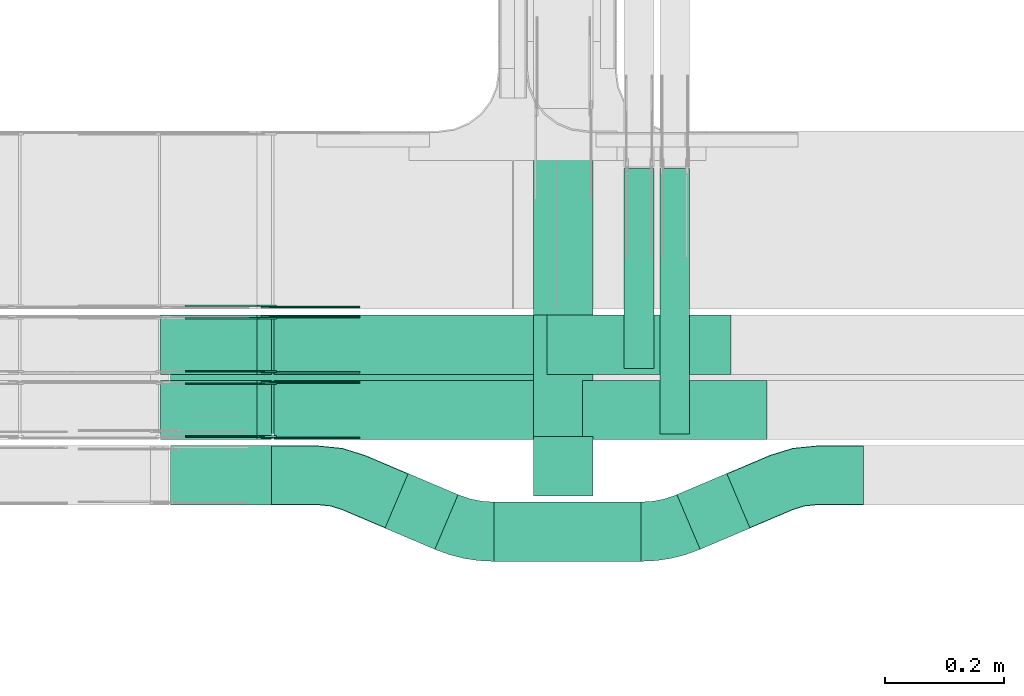
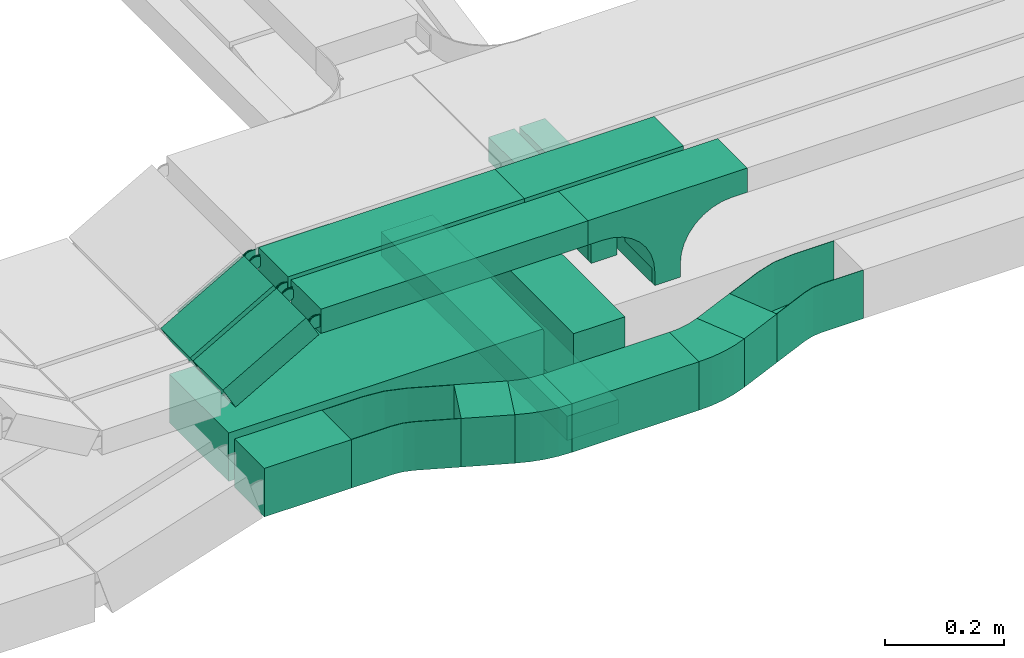
# One storey, part 12 of 28: 17 flow fittings, 13 flow segments.
"""IFC2X3 building model written with IfcOpenShell, lengths in millimetres."""

from ifc_helpers import new_model, entity, si_unit, converted_unit, derived_unit, direction, frame, frame_2d, origin, origin_2d_with_axis, place, context, subcontext, project, spatial, polyline, circle_curve, parameter, trimmed, segment, composite_curve, rectangle, outline, extrude, faceted_brep, source, transform, mapped, material, material_list, type_object, type_shapes, element, save


model = new_model("IFC2X3")

# Units and contexts
model_context = context("Model", 3, precision=0.01, world=origin(), true_north=direction((6.12303176911189e-17, 1.0)))
body_context = subcontext(model_context, "Body", "Model", "MODEL_VIEW")
ifc_project = project(units=[si_unit("LENGTHUNIT", "METRE", prefix="MILLI"), si_unit("AREAUNIT", "SQUARE_METRE"), si_unit("VOLUMEUNIT", "CUBIC_METRE"), converted_unit("PLANEANGLEUNIT", "DEGREE", entity("IfcRatioMeasure", 0.0174532925199433), si_unit("PLANEANGLEUNIT", "RADIAN"), dimensions=[0, 0, 0, 0, 0, 0, 0]), si_unit("MASSUNIT", "GRAM", prefix="KILO"), derived_unit("MASSDENSITYUNIT", [(si_unit("MASSUNIT", "GRAM", prefix="KILO"), 1), (si_unit("LENGTHUNIT", "METRE"), -3)]), derived_unit("MOMENTOFINERTIAUNIT", [(si_unit("LENGTHUNIT", "METRE"), 4)]), si_unit("TIMEUNIT", "SECOND"), si_unit("FREQUENCYUNIT", "HERTZ"), si_unit("THERMODYNAMICTEMPERATUREUNIT", "DEGREE_CELSIUS"), derived_unit("THERMALTRANSMITTANCEUNIT", [(si_unit("MASSUNIT", "GRAM", prefix="KILO"), 1), (si_unit("THERMODYNAMICTEMPERATUREUNIT", "KELVIN"), -1), (si_unit("TIMEUNIT", "SECOND"), -3)]), derived_unit("VOLUMETRICFLOWRATEUNIT", [(si_unit("LENGTHUNIT", "METRE"), 3), (si_unit("TIMEUNIT", "SECOND"), -1)]), derived_unit("MASSFLOWRATEUNIT", [(si_unit("MASSUNIT", "GRAM", prefix="KILO"), 1), (si_unit("TIMEUNIT", "SECOND"), -1)]), derived_unit("ROTATIONALFREQUENCYUNIT", [(si_unit("TIMEUNIT", "SECOND"), -1)]), si_unit("ELECTRICCURRENTUNIT", "AMPERE"), si_unit("ELECTRICVOLTAGEUNIT", "VOLT"), si_unit("POWERUNIT", "WATT"), si_unit("FORCEUNIT", "NEWTON", prefix="KILO"), si_unit("ILLUMINANCEUNIT", "LUX"), si_unit("LUMINOUSFLUXUNIT", "LUMEN"), si_unit("LUMINOUSINTENSITYUNIT", "CANDELA"), derived_unit("USERDEFINED", [(si_unit("MASSUNIT", "GRAM", prefix="KILO"), -1), (si_unit("LENGTHUNIT", "METRE"), -2), (si_unit("TIMEUNIT", "SECOND"), 3), (si_unit("LUMINOUSFLUXUNIT", "LUMEN"), 1)]), derived_unit("LINEARVELOCITYUNIT", [(si_unit("LENGTHUNIT", "METRE"), 1), (si_unit("TIMEUNIT", "SECOND"), -1)]), si_unit("PRESSUREUNIT", "PASCAL"), derived_unit("USERDEFINED", [(si_unit("LENGTHUNIT", "METRE"), -2), (si_unit("MASSUNIT", "GRAM", prefix="KILO"), 1), (si_unit("TIMEUNIT", "SECOND"), -2)]), derived_unit("LINEARFORCEUNIT", [(si_unit("MASSUNIT", "GRAM", prefix="KILO"), 1), (si_unit("LENGTHUNIT", "METRE"), 1), (si_unit("TIMEUNIT", "SECOND"), -2), (si_unit("LENGTHUNIT", "METRE"), -1)]), derived_unit("PLANARFORCEUNIT", [(si_unit("MASSUNIT", "GRAM", prefix="KILO"), 1), (si_unit("LENGTHUNIT", "METRE"), 1), (si_unit("TIMEUNIT", "SECOND"), -2), (si_unit("LENGTHUNIT", "METRE"), -2)])], contexts=[model_context])

# Site, building, storey
site_placement = place(None, frame((0.0, -0.00077364408347762, 0.0)))
site = spatial("IfcSite", under=ifc_project, at=site_placement, CompositionType="ELEMENT")
building_placement = place(site_placement, origin())
building = spatial("IfcBuilding", under=site, at=building_placement, CompositionType="ELEMENT")
storey_placement = place(building_placement, origin())
storey = spatial("IfcBuildingStorey", under=building, at=storey_placement, CompositionType="ELEMENT", Elevation=0.0)

# Flow segments
cable_carrier_segment_type = type_object("IfcCableCarrierSegmentType", PredefinedType="CABLETRAYSEGMENT")
flow_segment_1_placement = place(storey_placement, frame((35767.4596505076, 8409.92379591468, 2721.0)))
element("IfcFlowSegment", 1, at=flow_segment_1_placement, inside=storey, type_object=cable_carrier_segment_type, context=body_context, shape_type="SweptSolid", body=[
    extrude(rectangle(XDim=446.583630582365, YDim=49.9999999999973, at=frame_2d((-5.54223333892878e-13, 0.0), x_axis=(1.0, 0.0))), frame((25.0, 223.291815291182, 0.0), z_axis=(0.0, 0.0, 1.0), x_axis=(0.0, -1.0, 0.0)), (0.0, 0.0, 1.0), 50.0000000000005),
])
flow_segment_2_placement = place(storey_placement, frame((35488.3513895531, 8195.26374193012, 2600.0)))
element("IfcFlowSegment", 2, at=flow_segment_2_placement, inside=storey, type_object=cable_carrier_segment_type, context=body_context, shape_type="SweptSolid", body=[
    extrude(rectangle(XDim=247.288948924523, YDim=99.9999999999989, at=frame_2d((0.0, -5.40012479177676e-13), x_axis=(1.0, 0.0))), frame((123.644474462261, 50.0, 0.0)), (0.0, 0.0, 1.0), 100.0),
])
flow_segment_3_placement = place(storey_placement, frame((35304.8154739115, 8215.5282596955, 2600.0)))
element("IfcFlowSegment", 3, at=flow_segment_3_placement, inside=storey, type_object=cable_carrier_segment_type, context=body_context, shape_type="SweptSolid", body=[
    extrude(rectangle(XDim=91.1810821540981, YDim=100.000000000001, at=frame_2d((4.2277292777726e-13, -9.98312543742941e-13), x_axis=(1.0, 0.0))), frame((61.5028707574128, 63.8388862360975, 0.0), z_axis=(0.0, 0.0, 1.0), x_axis=(0.920504853452403, -0.390731128489362, 0.0)), (0.0, 0.0, 1.0), 100.0),
])
flow_segment_4_placement = place(storey_placement, frame((34944.2305815425, 8290.00006103516, 2600.0)))
element("IfcFlowSegment", 4, at=flow_segment_4_placement, inside=storey, type_object=cable_carrier_segment_type, context=body_context, shape_type="SweptSolid", body=[
    extrude(rectangle(XDim=169.658005217947, YDim=99.9999999999989, at=frame_2d((0.0, 5.40012479177676e-13), x_axis=(1.0, 0.0))), frame((84.8290026089778, 50.0, 0.0), z_axis=(0.0, 0.0, 1.0), x_axis=(-1.0, 0.0, 0.0)), (0.0, 0.0, 1.0), 100.000000000001),
])
flow_segment_5_placement = place(storey_placement, frame((35555.108534959, 8327.89179254256, 2520.11776562736)))
element("IfcFlowSegment", 5, at=flow_segment_5_placement, inside=storey, type_object=cable_carrier_segment_type, context=body_context, shape_type="SweptSolid", body=[
    extrude(rectangle(XDim=626.717650502026, YDim=100.000000000003, at=origin_2d_with_axis()), frame((50.0, 313.358825251013, 0.0), z_axis=(0.0, 0.0, 1.0), x_axis=(0.0, -1.0, 0.0)), (0.0, 0.0, 1.0), 50.0000000000005),
])
flow_segment_6_placement = place(storey_placement, frame((34944.2305815425, 8410.17178445353, 2600.0)))
element("IfcFlowSegment", 6, at=flow_segment_6_placement, inside=storey, type_object=cable_carrier_segment_type, context=body_context, shape_type="SweptSolid", body=[
    extrude(rectangle(XDim=660.477953416512, YDim=200.0, at=frame_2d((2.1600499167107e-12, 5.47117906535277e-13), x_axis=(1.0, 0.0))), frame((330.238976708254, 100.0, 0.0), z_axis=(0.0, 0.0, 1.0), x_axis=(-1.0, 0.0, 0.0)), (0.0, 0.0, 1.0), 100.0),
])
flow_segment_7_placement = place(storey_placement, frame((35555.108534959, 8305.17178445353, 2570.11776562736)))
element("IfcFlowSegment", 7, at=flow_segment_7_placement, inside=storey, type_object=cable_carrier_segment_type, context=body_context, shape_type="SweptSolid", body=[
    extrude(rectangle(XDim=100.000000000003, YDim=100.000000000001, at=origin_2d_with_axis()), frame((50.0, 50.0, 0.0), z_axis=(0.0, 0.0, 1.0), x_axis=(-1.0, 0.0, 0.0)), (0.0, 0.0, 1.0), 50.8822343726412),
])
flow_segment_8_placement = place(storey_placement, frame((35796.1705126045, 8215.5282596955, 2600.0)))
element("IfcFlowSegment", 8, at=flow_segment_8_placement, inside=storey, type_object=cable_carrier_segment_type, context=body_context, shape_type="SweptSolid", body=[
    extrude(rectangle(XDim=91.1810821540889, YDim=100.000000000001, at=frame_2d((-2.1316282072803e-13, -5.00932628710871e-13), x_axis=(1.0, 0.0))), frame((61.5028707574085, 63.8388862360954, 0.0), z_axis=(0.0, 0.0, 1.0), x_axis=(-0.920504853452401, -0.390731128489366, 0.0)), (0.0, 0.0, 1.0), 99.9999999999999),
])
flow_segment_9_placement = place(storey_placement, frame((35117.8214366613, 8510.00006103506, 2850.0)))
element("IfcFlowSegment", 9, at=flow_segment_9_placement, inside=storey, type_object=cable_carrier_segment_type, context=body_context, shape_type="SweptSolid", body=[
    extrude(rectangle(XDim=459.62214617131, YDim=100.000000000001, at=frame_2d((-2.17426077142591e-12, 5.43565192856477e-13), x_axis=(1.0, 0.0))), frame((229.811073085657, 50.0, 0.0), z_axis=(0.0, 0.0, 1.0), x_axis=(-1.0, 0.0, 0.0)), (0.0, 0.0, 1.0), 50.0000000000011),
])
flow_segment_10_placement = place(storey_placement, frame((35117.8214366612, 8400.00006103518, 2850.0)))
element("IfcFlowSegment", 10, at=flow_segment_10_placement, inside=storey, type_object=cable_carrier_segment_type, context=body_context, shape_type="SweptSolid", body=[
    extrude(rectangle(XDim=519.774157422868, YDim=100.000000000001, at=frame_2d((2.1600499167107e-12, -5.43565192856477e-13), x_axis=(1.0, 0.0))), frame((259.887078711436, 50.0, 0.0), z_axis=(0.0, 0.0, 1.0), x_axis=(-1.0, 0.0, 0.0)), (0.0, 0.0, 1.0), 50.0000000000005),
])
flow_segment_11_placement = place(storey_placement, frame((34927.1059649383, 8400.00006103519, 2756.67195783193)))
element("IfcFlowSegment", 11, at=flow_segment_11_placement, inside=storey, type_object=cable_carrier_segment_type, context=body_context, shape_type="SweptSolid", body=[
    extrude(rectangle(XDim=49.999999999999, YDim=100.000000000001, at=frame_2d((1.64490643328463e-12, 0.0), x_axis=(1.0, 0.0))), frame((12.3695839738717, 50.0, 21.7254089101553), z_axis=(0.869016356406197, 0.0, 0.494783358954703), x_axis=(-0.494783358954703, 0.0, 0.869016356406197)), (0.0, 0.0, 1.0), 186.565135152812),
])
flow_segment_12_placement = place(storey_placement, frame((34927.1059649383, 8510.00006103506, 2756.67195783192)))
element("IfcFlowSegment", 12, at=flow_segment_12_placement, inside=storey, type_object=cable_carrier_segment_type, context=body_context, shape_type="SweptSolid", body=[
    extrude(rectangle(XDim=49.9999999999996, YDim=100.000000000001, at=frame_2d((2.36255459640233e-13, 0.0), x_axis=(1.0, 0.0))), frame((12.369583973863, 50.0, 21.7254089101602), z_axis=(0.869016356406348, 0.0, 0.494783358954437), x_axis=(-0.494783358954437, 0.0, 0.869016356406348)), (0.0, 0.0, 1.0), 186.565135152931),
])
flow_segment_13_placement = place(storey_placement, frame((35707.4596505076, 8520.26288830365, 2721.0)))
element("IfcFlowSegment", 13, at=flow_segment_13_placement, inside=storey, type_object=cable_carrier_segment_type, context=body_context, shape_type="SweptSolid", body=[
    extrude(rectangle(XDim=336.244538193396, YDim=49.9999999999973, at=origin_2d_with_axis()), frame((25.0, 168.122269096698, 0.0), z_axis=(0.0, 0.0, 1.0), x_axis=(0.0, -1.0, 0.0)), (0.0, 0.0, 1.0), 50.0000000000005),
])

# Flow fittings
ifc_material_1 = material(Name="G")
cable_carrier_fitting_type_1 = type_object("IfcCableCarrierFittingType", PredefinedType="NOTDEFINED", material=ifc_material_1)
shared_shape_1 = source(origin(), body_context, "Body", "SweptSolid", [
    extrude(outline(composite_curve([segment(trimmed(circle_curve(frame_2d((-44.5901162790698, 0.0), x_axis=(1.0, 0.0)), 12.5), [parameter(90.0000000000007)], [parameter(270.0)], True, "PARAMETER"), True, "CONTINUOUS"), segment(polyline([(-44.5901162790697, -12.5), (-33.0901162790698, -12.5)]), True, "CONTINUOUS"), segment(polyline([(-33.0901162790698, -12.5), (-31.2296511627907, -14.5)]), True, "CONTINUOUS"), segment(polyline([(-31.2296511627907, -14.5), (108.90988372093, -14.5)]), True, "CONTINUOUS"), segment(polyline([(108.90988372093, -14.5), (108.90988372093, 14.5)]), True, "CONTINUOUS"), segment(polyline([(108.90988372093, 14.5), (-31.2296511627907, 14.5)]), True, "CONTINUOUS"), segment(polyline([(-31.2296511627907, 14.5), (-33.0901162790698, 12.5)]), True, "CONTINUOUS"), segment(polyline([(-33.0901162790698, 12.5), (-44.5901162790699, 12.5)]), True, "CONTINUOUS")], self_intersect=False)), frame((44.5901162790698, 0.0, 0.0), z_axis=(0.0, 0.0, -1.0), x_axis=(1.0, 0.0, 0.0)), (0.0, 0.0, -1.0), 2.0),
])
type_shapes(cable_carrier_fitting_type_1, [shared_shape_1])
for number, where, z_axis, x_axis in (
    (14, (35109.1442874696, 8495.46006104534, 2875.0), (0.0, 1.0, 0.0), (1.0, 0.0, 0.0)),
    (15, (35109.1442874697, 8605.46006104522, 2875.0), (0.0, 1.0, 0.0), (1.0, 0.0, 0.0)),
):
    element("IfcFlowFitting", number, at=place(storey_placement, frame(where, z_axis=z_axis, x_axis=x_axis)), inside=storey, type_object=cable_carrier_fitting_type_1, material=ifc_material_1, context=body_context, shape_type="MappedRepresentation", body=[
        mapped(shared_shape_1, transform((0.0, 0.0, 0.0), scale=1.0)),
    ])
cable_carrier_fitting_type_2 = type_object("IfcCableCarrierFittingType", PredefinedType="NOTDEFINED", material=ifc_material_1)
shared_shape_2 = source(origin(), body_context, "Body", "SweptSolid", [
    extrude(outline(composite_curve([segment(trimmed(circle_curve(frame_2d((-44.5901162790697, 0.0), x_axis=(1.0, 0.0)), 12.5), [parameter(90.0000000000007)], [parameter(270.0)], True, "PARAMETER"), True, "CONTINUOUS"), segment(polyline([(-44.5901162790697, -12.5), (-33.0901162790697, -12.5)]), True, "CONTINUOUS"), segment(polyline([(-33.0901162790697, -12.5), (-31.2296511627907, -14.5)]), True, "CONTINUOUS"), segment(polyline([(-31.2296511627907, -14.5), (108.90988372093, -14.5)]), True, "CONTINUOUS"), segment(polyline([(108.90988372093, -14.5), (108.90988372093, 14.5)]), True, "CONTINUOUS"), segment(polyline([(108.90988372093, 14.5), (-31.2296511627907, 14.5)]), True, "CONTINUOUS"), segment(polyline([(-31.2296511627907, 14.5), (-33.0901162790698, 12.5)]), True, "CONTINUOUS"), segment(polyline([(-33.0901162790698, 12.5), (-44.5901162790699, 12.5)]), True, "CONTINUOUS")], self_intersect=False)), frame((44.5901162790697, 0.0, 0.0)), (0.0, 0.0, 1.0), 2.0),
])
type_shapes(cable_carrier_fitting_type_2, [shared_shape_2])
for number, where, z_axis, x_axis in (
    (16, (35109.1442874696, 8404.54006102502, 2875.0), (0.0, -1.0, 0.0), (1.0, 0.0, 0.0)),
    (17, (35109.1442874697, 8514.5400610249, 2875.0), (0.0, -1.0, 0.0), (1.0, 0.0, 0.0)),
    (18, (35109.1442874699, 8624.54006102497, 2875.0), (0.0, -1.0, 0.0), (1.0, 0.0, 0.0)),
):
    element("IfcFlowFitting", number, at=place(storey_placement, frame(where, z_axis=z_axis, x_axis=x_axis)), inside=storey, type_object=cable_carrier_fitting_type_2, material=ifc_material_1, context=body_context, shape_type="MappedRepresentation", body=[
        mapped(shared_shape_2, transform((0.0, 0.0, 0.0), scale=1.0)),
    ])
cable_carrier_fitting_type_3 = type_object("IfcCableCarrierFittingType", PredefinedType="NOTDEFINED", material=ifc_material_1)
shared_shape_3 = source(origin(), body_context, "Body", "SweptSolid", [
    extrude(outline(composite_curve([segment(trimmed(circle_curve(frame_2d((-44.5901162790698, 0.0), x_axis=(1.0, 0.0)), 12.5), [parameter(90.0000000000007)], [parameter(270.0)], True, "PARAMETER"), True, "CONTINUOUS"), segment(polyline([(-44.5901162790697, -12.5), (-33.0901162790698, -12.5)]), True, "CONTINUOUS"), segment(polyline([(-33.0901162790698, -12.5), (-31.2296511627907, -14.5)]), True, "CONTINUOUS"), segment(polyline([(-31.2296511627907, -14.5), (108.90988372093, -14.5)]), True, "CONTINUOUS"), segment(polyline([(108.90988372093, -14.5), (108.90988372093, 14.5)]), True, "CONTINUOUS"), segment(polyline([(108.90988372093, 14.5), (-31.2296511627907, 14.5)]), True, "CONTINUOUS"), segment(polyline([(-31.2296511627907, 14.5), (-33.0901162790698, 12.5)]), True, "CONTINUOUS"), segment(polyline([(-33.0901162790698, 12.5), (-44.5901162790699, 12.5)]), True, "CONTINUOUS")], self_intersect=False)), frame((44.5901162790698, 0.0, 0.0), z_axis=(0.0, 0.0, -1.0), x_axis=(1.0, 0.0, 0.0)), (0.0, 0.0, -1.0), 2.0),
])
type_shapes(cable_carrier_fitting_type_3, [shared_shape_3])
for number, where, z_axis, x_axis in (
    (19, (35109.1442874696, 8406.54006102502, 2875.0), (0.0, -1.0, 0.0), (-0.869016356406185, 0.0, -0.494783358954723)),
    (20, (35109.1442874697, 8516.5400610249, 2875.0), (0.0, -1.0, 0.0), (-0.869016356406364, 0.0, -0.494783358954409)),
    (21, (35109.1442874699, 8626.54006102497, 2875.0), (0.0, -1.0, 0.0), (-0.869016356406542, 0.0, -0.494783358954097)),
):
    element("IfcFlowFitting", number, at=place(storey_placement, frame(where, z_axis=z_axis, x_axis=x_axis)), inside=storey, type_object=cable_carrier_fitting_type_3, material=ifc_material_1, context=body_context, shape_type="MappedRepresentation", body=[
        mapped(shared_shape_3, transform((0.0, 0.0, 0.0), scale=1.0)),
    ])
cable_carrier_fitting_type_4 = type_object("IfcCableCarrierFittingType", PredefinedType="NOTDEFINED", material=ifc_material_1)
shared_shape_4 = source(origin(), body_context, "Body", "SweptSolid", [
    extrude(outline(composite_curve([segment(trimmed(circle_curve(frame_2d((-44.5901162790697, 0.0), x_axis=(1.0, 0.0)), 12.5), [parameter(90.0000000000007)], [parameter(270.0)], True, "PARAMETER"), True, "CONTINUOUS"), segment(polyline([(-44.5901162790697, -12.5), (-33.0901162790697, -12.5)]), True, "CONTINUOUS"), segment(polyline([(-33.0901162790697, -12.5), (-31.2296511627907, -14.5)]), True, "CONTINUOUS"), segment(polyline([(-31.2296511627907, -14.5), (108.90988372093, -14.5)]), True, "CONTINUOUS"), segment(polyline([(108.90988372093, -14.5), (108.90988372093, 14.5)]), True, "CONTINUOUS"), segment(polyline([(108.90988372093, 14.5), (-31.2296511627907, 14.5)]), True, "CONTINUOUS"), segment(polyline([(-31.2296511627907, 14.5), (-33.0901162790698, 12.5)]), True, "CONTINUOUS"), segment(polyline([(-33.0901162790698, 12.5), (-44.5901162790699, 12.5)]), True, "CONTINUOUS")], self_intersect=False)), frame((44.5901162790697, 0.0, 0.0)), (0.0, 0.0, 1.0), 2.0),
])
type_shapes(cable_carrier_fitting_type_4, [shared_shape_4])
for number, where, z_axis, x_axis in (
    (22, (35109.1442874696, 8493.46006104534, 2875.0), (0.0, 1.0, 0.0), (-0.869016356406185, 0.0, -0.494783358954723)),
    (23, (35109.1442874697, 8603.46006104522, 2875.0), (0.0, 1.0, 0.0), (-0.869016356406364, 0.0, -0.494783358954409)),
):
    element("IfcFlowFitting", number, at=place(storey_placement, frame(where, z_axis=z_axis, x_axis=x_axis)), inside=storey, type_object=cable_carrier_fitting_type_4, material=ifc_material_1, context=body_context, shape_type="MappedRepresentation", body=[
        mapped(shared_shape_4, transform((0.0, 0.0, 0.0), scale=1.0)),
    ])
ifc_material_2 = material()
ifc_material_list = material_list([ifc_material_2, ifc_material_2, ifc_material_2, ifc_material_2, ifc_material_2])
cable_carrier_fitting_type_5 = type_object("IfcCableCarrierFittingType", PredefinedType="NOTDEFINED", material=ifc_material_list)
shared_shape_5 = source(origin(), body_context, "Body", "SweptSolid", [
    extrude(outline(composite_curve([segment(polyline([(-61.8571428571422, -174.285714285714), (-7.85714285714298, -174.285714285714)]), True, "CONTINUOUS"), segment(polyline([(-7.85714285714298, -174.285714285714), (-7.85714285714366, 25.7142857142864)]), True, "CONTINUOUS"), segment(trimmed(circle_curve(frame_2d((-2.85714285714366, 25.7142857142864), x_axis=(0.0, -1.0)), 5.0), [parameter(180.0)], [parameter(270.0)], True, "PARAMETER"), False, "CONTINUOUS"), segment(polyline([(-2.85714285714365, 30.7142857142857), (71.1428571428574, 30.7142857142857)]), True, "CONTINUOUS"), segment(polyline([(71.1428571428574, 30.7142857142857), (71.1428571428574, 130.714285714286)]), True, "CONTINUOUS"), segment(polyline([(71.1428571428574, 130.714285714286), (-61.8571428571422, 130.714285714286)]), True, "CONTINUOUS"), segment(polyline([(-61.8571428571422, 130.714285714286), (-61.8571428571422, -174.285714285714)]), True, "CONTINUOUS")], self_intersect=False)), frame((-74.2857142857142, -50.0, 42.1428571428574), z_axis=(0.0, 1.0, 0.0), x_axis=(0.0, 0.0, -1.0)), (0.0, 0.0, 1.0), 0.800000000000055),
    extrude(rectangle(XDim=0.799999999999954, YDim=100.0, at=origin_2d_with_axis()), frame((99.6, 0.0, 17.5000000000609), z_axis=(0.0, 0.0, 1.0), x_axis=(-1.0, 0.0, 0.0)), (0.0, 0.0, 1.0), 86.4999999999732),
    extrude(rectangle(XDim=305.0, YDim=100.0, at=origin_2d_with_axis()), frame((-52.4999999999998, 0.0, 103.199999999999), z_axis=(0.0, 0.0, 1.0), x_axis=(-1.0, 0.0, 0.0)), (0.0, 0.0, 1.0), 0.800000000000106),
    extrude(rectangle(XDim=0.799999999999852, YDim=98.4000000000001, at=frame_2d((-1.69309011255336e-14, 0.0), x_axis=(1.0, 0.0))), frame((-204.6, 0.0, -29.0), z_axis=(0.0, 0.0, 1.0), x_axis=(-1.0, 0.0, 0.0)), (0.0, 0.0, 1.0), 133.0),
    extrude(outline(composite_curve([segment(polyline([(-61.8571428571426, -174.285714285714), (-7.8571428571429, -174.285714285714)]), True, "CONTINUOUS"), segment(polyline([(-7.8571428571429, -174.285714285714), (-7.8571428571429, 25.7142857142858)]), True, "CONTINUOUS"), segment(trimmed(circle_curve(frame_2d((-2.85714285714291, 25.7142857142858), x_axis=(0.0, -1.0)), 5.0), [parameter(180.0)], [parameter(270.0)], True, "PARAMETER"), False, "CONTINUOUS"), segment(polyline([(-2.85714285714293, 30.7142857142858), (71.1428571428569, 30.7142857142858)]), True, "CONTINUOUS"), segment(polyline([(71.1428571428569, 30.7142857142858), (71.1428571428569, 130.714285714286)]), True, "CONTINUOUS"), segment(polyline([(71.1428571428569, 130.714285714286), (-61.8571428571426, 130.714285714286)]), True, "CONTINUOUS"), segment(polyline([(-61.8571428571426, 130.714285714286), (-61.8571428571426, -174.285714285714)]), True, "CONTINUOUS")], self_intersect=False)), frame((-74.2857142857142, 49.2000000000002, 42.1428571428575), z_axis=(0.0, 1.0, 0.0), x_axis=(0.0, 0.0, -1.0)), (0.0, 0.0, 1.0), 0.799999999999835),
])
type_shapes(cable_carrier_fitting_type_5, [shared_shape_5])
flow_fitting_1_placement = place(storey_placement, frame((35605.108534959, 8510.17178445353, 2650.0), z_axis=(0.0, 0.0, 1.0), x_axis=(0.0, 1.0, 0.0)))
element("IfcFlowFitting", 24, at=flow_fitting_1_placement, inside=storey, type_object=cable_carrier_fitting_type_5, material=ifc_material_2, Name="470_DKC_S5_vertical T-shaped cover", context=body_context, shape_type="MappedRepresentation", body=[
    mapped(shared_shape_5, transform((0.0, 0.0, 0.0), scale=1.0)),
])
cable_carrier_fitting_type_6 = type_object("IfcCableCarrierFittingType", PredefinedType="NOTDEFINED", material=ifc_material_2)
shared_shape_6 = source(origin(), body_context, "Body", "SweptSolid", [
    extrude(outline(composite_curve([segment(polyline([(-155.0, -85.7999999999954), (155.0, -85.7999999999954)]), True, "CONTINUOUS"), segment(polyline([(155.0, -85.7999999999954), (155.0, -35.7999999999878)]), True, "CONTINUOUS"), segment(polyline([(155.0, -35.7999999999878), (125.0, -35.7999999999878)]), True, "CONTINUOUS"), segment(trimmed(circle_curve(frame_2d((125.0, 64.2000000000048), x_axis=(1.0, 0.0)), 99.9999999999926), [parameter(180.0)], [parameter(269.999999999985)], True, "PARAMETER"), False, "CONTINUOUS"), segment(polyline([(25.0, 64.2000000000045), (25.0, 93.2000000000039)]), True, "CONTINUOUS"), segment(polyline([(25.0, 93.2000000000039), (-25.0, 93.2000000000039)]), True, "CONTINUOUS"), segment(polyline([(-25.0, 93.2000000000039), (-25.0, 64.1999999999235)]), True, "CONTINUOUS"), segment(trimmed(circle_curve(frame_2d((-125.0, 64.2000000000028), x_axis=(1.0, 0.0)), 99.9999999999768), [parameter(270.0)], [parameter(359.999999999955)], True, "PARAMETER"), False, "CONTINUOUS"), segment(polyline([(-125.0, -35.799999999974), (-155.0, -35.7999999999955)]), True, "CONTINUOUS"), segment(polyline([(-155.0, -35.7999999999955), (-155.0, -85.7999999999954)]), True, "CONTINUOUS")], self_intersect=False)), frame((155.0, -50.0, -60.7999999999977), z_axis=(0.0, 1.0, 0.0), x_axis=(1.0, 0.0, 0.0)), (0.0, 0.0, 1.0), 100.0),
])
type_shapes(cable_carrier_fitting_type_6, [shared_shape_6])
for number, where, z_axis, x_axis in (
    (25, (35887.4435828326, 8560.00006103504, 2875.0), (0.0, 0.0, 1.0), (-1.0, 0.0, 0.0)),
    (26, (35947.5955940841, 8450.00006103516, 2875.0), (0.0, 0.0, 1.0), (-1.0, 0.0, 0.0)),
):
    element("IfcFlowFitting", number, at=place(storey_placement, frame(where, z_axis=z_axis, x_axis=x_axis)), inside=storey, type_object=cable_carrier_fitting_type_6, material=ifc_material_2, context=body_context, shape_type="MappedRepresentation", body=[
        mapped(shared_shape_6, transform((0.0, 0.0, 0.0), scale=1.0)),
    ])
cable_carrier_fitting_type_7 = type_object("IfcCableCarrierFittingType", Name="470_DKC_S5_Variable Angle Elbow 0-45:-", PredefinedType="NOTDEFINED", material=ifc_material_2)
shared_shape_7 = source(origin(), body_context, "Body", "SweptSolid", [
    extrude(outline(composite_curve([segment(polyline([(-40.0532390622913, -58.0471974368788), (-39.05323906229, -58.0471974368788)]), True, "CONTINUOUS"), segment(trimmed(circle_curve(frame_2d((-39.0532390622925, 191.952802563121), x_axis=(0.0, -1.0)), 250.0), [parameter(0.0)], [parameter(23.0000000000002)], True, "PARAMETER"), True, "CONTINUOUS"), segment(polyline([(58.6295430600289, -38.1734107999876), (59.5500479134813, -37.7826796714983)]), True, "CONTINUOUS"), segment(polyline([(59.5500479134813, -37.7826796714983), (20.4769350645528, 54.2678056737451)]), True, "CONTINUOUS"), segment(polyline([(20.4769350645528, 54.2678056737451), (19.5564302111003, 53.8770745452558)]), True, "CONTINUOUS"), segment(trimmed(circle_curve(frame_2d((-39.0532390622925, 191.952802563121), x_axis=(0.0, -1.0)), 150.0), [parameter(0.0)], [parameter(23.0000000000002)], True, "PARAMETER"), False, "CONTINUOUS"), segment(polyline([(-39.0532390622908, 41.9528025631211), (-40.0532390622921, 41.9528025631211)]), True, "CONTINUOUS"), segment(polyline([(-40.0532390622921, 41.9528025631211), (-40.0532390622913, -58.0471974368788)]), True, "CONTINUOUS")], self_intersect=False)), frame((-1.63722082243969, 8.04719743687039, -50.0)), (0.0, 0.0, 1.0), 100.0),
])
type_shapes(cable_carrier_fitting_type_7, [shared_shape_7])
flow_fitting_2_placement = place(storey_placement, frame((35446.6609296684, 8245.26374193014, 2650.0), z_axis=(0.0, 0.0, 1.0), x_axis=(0.920504853452443, -0.390731128489267, 0.0)))
element("IfcFlowFitting", 27, at=flow_fitting_2_placement, inside=storey, type_object=cable_carrier_fitting_type_7, material=ifc_material_2, Name="470_DKC_S5_Variable Angle Elbow 0-45:-", ObjectType="470_DKC_S5_Variable Angle Elbow 0-45:-", context=body_context, shape_type="MappedRepresentation", body=[
    mapped(shared_shape_7, transform((0.0, 0.0, 0.0), scale=1.0)),
])
flow_fitting_3_placement = place(storey_placement, frame((35777.3307983624, 8245.26374193014, 2650.0)))
element("IfcFlowFitting", 28, at=flow_fitting_3_placement, inside=storey, type_object=cable_carrier_fitting_type_7, material=ifc_material_2, Name="470_DKC_S5_Variable Angle Elbow 0-45:-", ObjectType="470_DKC_S5_Variable Angle Elbow 0-45:-", context=body_context, shape_type="MappedRepresentation", body=[
    mapped(shared_shape_7, transform((0.0, 0.0, 0.0), scale=1.0)),
])
cable_carrier_fitting_type_8 = type_object("IfcCableCarrierFittingType", Name="470_DKC_S5_CPO 45 horizontal angle:-", PredefinedType="NOTDEFINED", material=ifc_material_2)
shared_shape_8 = source(origin(), body_context, "Body", "Brep", [
    faceted_brep([(-109.587561414997, -49.2000000000082, -49.2000000000019), (-109.587561414997, 49.1999999999917, -49.2000000000019), (-109.587561414997, 49.1999999999917, 50.0), (-109.587561414997, 50.0, 50.0), (-109.587561414997, 50.0, -50.0), (-109.587561414997, -50.0, -50.0), (-109.587561414997, -50.0, 50.0), (-109.587561414997, -49.2000000000082, 50.0), (-30.5178449135507, -50.0, -50.0), (-30.5178449135508, -50.0, 50.0), (9.35574196989491, -45.984940924173, 50.0), (47.6283807843155, -34.1009706904914, 50.0), (120.412438585003, -3.20597113254995, 50.0), (120.099853682212, -2.46956724978785, 50.0), (47.315795881524, -33.3645668077293, 50.0), (9.1962476223611, -45.2010011604762, 50.0), (-30.5178449135508, -49.2000000000082, 50.0), (-30.5178449135508, 49.1999999999917, 50.0), (-10.4215571242943, 51.2235897742128, 50.0), (8.8678528381736, 57.2131107719883, 50.0), (81.6519106388614, 88.1081103299299, 50.0), (81.3393257360699, 88.8445142126916, 50.0), (8.55526793538224, 57.9495146547501, 50.0), (-10.5810514718281, 52.0075295379093, 50.0), (-30.5178449135508, 50.0, 50.0), (-30.5178449135508, -49.2000000000082, -49.2000000000019), (9.1962476223611, -45.2010011604762, -49.2000000000019), (47.315795881524, -33.3645668077293, -49.2000000000019), (120.099853682212, -2.46956724978785, -49.2000000000019), (81.6519106388614, 88.1081103299299, -49.2000000000019), (8.86785283817365, 57.2131107719883, -49.2000000000019), (-10.4215571242943, 51.2235897742128, -49.2000000000019), (-30.5178449135508, 49.1999999999917, -49.2000000000019), (-30.5178449135508, 50.0, -50.0), (-10.5810514718281, 52.0075295379093, -50.0), (8.5552679353822, 57.9495146547501, -50.0), (81.33932573607, 88.8445142126916, -50.0), (120.412438585003, -3.20597113254995, -50.0), (47.6283807843156, -34.1009706904914, -50.0), (9.35574196989491, -45.984940924173, -50.0)], [[[0, 1, 2, 3, 4, 5, 6, 7]], [[6, 5, 8, 9]], [[6, 9, 10, 11, 12, 13, 14, 15, 16, 7]], [[2, 17, 18, 19, 20, 21, 22, 23, 24, 3]], [[0, 7, 16, 25]], [[0, 25, 26, 27, 28, 29, 30, 31, 32, 1]], [[2, 1, 32, 17]], [[4, 3, 24, 33]], [[4, 33, 34, 35, 36, 37, 38, 39, 8, 5]], [[9, 8, 39, 10]], [[39, 38, 11, 10]], [[26, 25, 16, 15]], [[15, 14, 27, 26]], [[17, 32, 31, 18]], [[18, 31, 30, 19]], [[34, 33, 24, 23]], [[22, 35, 34, 23]], [[36, 21, 20, 29, 28, 13, 12, 37]], [[11, 38, 37, 12]], [[27, 14, 13, 28]], [[19, 30, 29, 20]], [[35, 22, 21, 36]]]),
])
type_shapes(cable_carrier_fitting_type_8, [shared_shape_8])
for number, where, z_axis, x_axis, name in (
    (29, (36000.5155798554, 8340.00006103515, 2650.0), (0.0, 0.0, 1.0), (-1.0, 0.0, 0.0), "470_DKC_S5_45 horizontal angle"),
    (30, (35223.4761481754, 8340.00006103514, 2650.0), (0.0, 0.0, 1.0), (-0.920504853452403, 0.390731128489362, 0.0), "470_DKC_S5_45 horizontal angle"),
):
    element("IfcFlowFitting", number, at=place(storey_placement, frame(where, z_axis=z_axis, x_axis=x_axis)), inside=storey, type_object=cable_carrier_fitting_type_8, material=ifc_material_2, Name=name, ObjectType="470_DKC_S5_CPO 45 horizontal angle:-", context=body_context, shape_type="MappedRepresentation", body=[
        mapped(shared_shape_8, transform((0.0, 0.0, 0.0), scale=1.0)),
    ])

save(model, "model.ifc")
